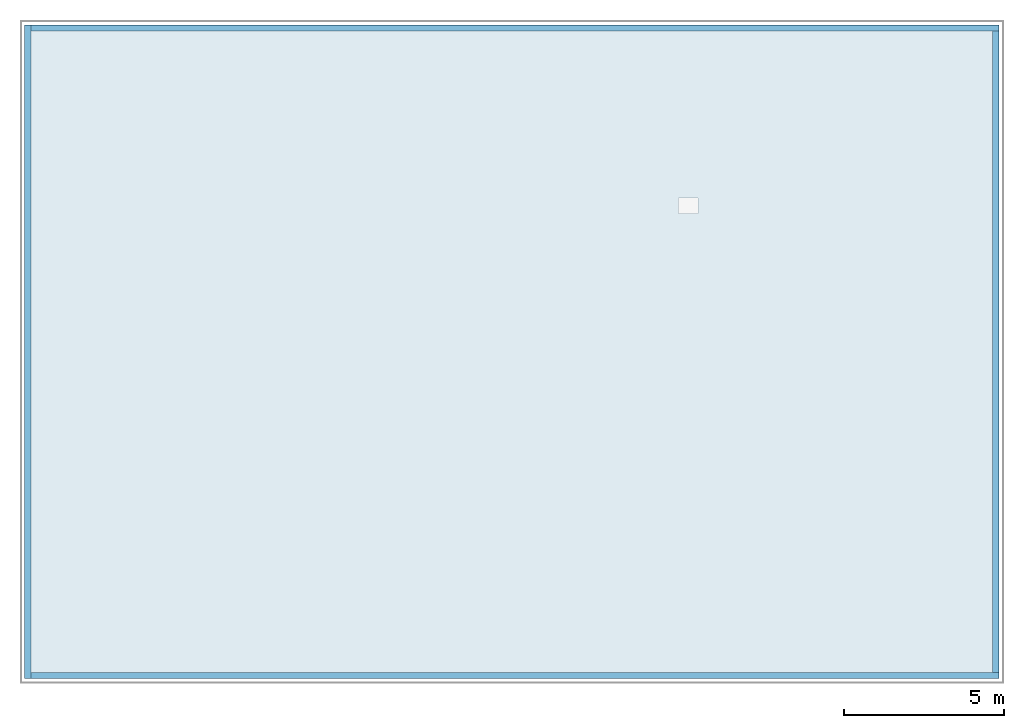
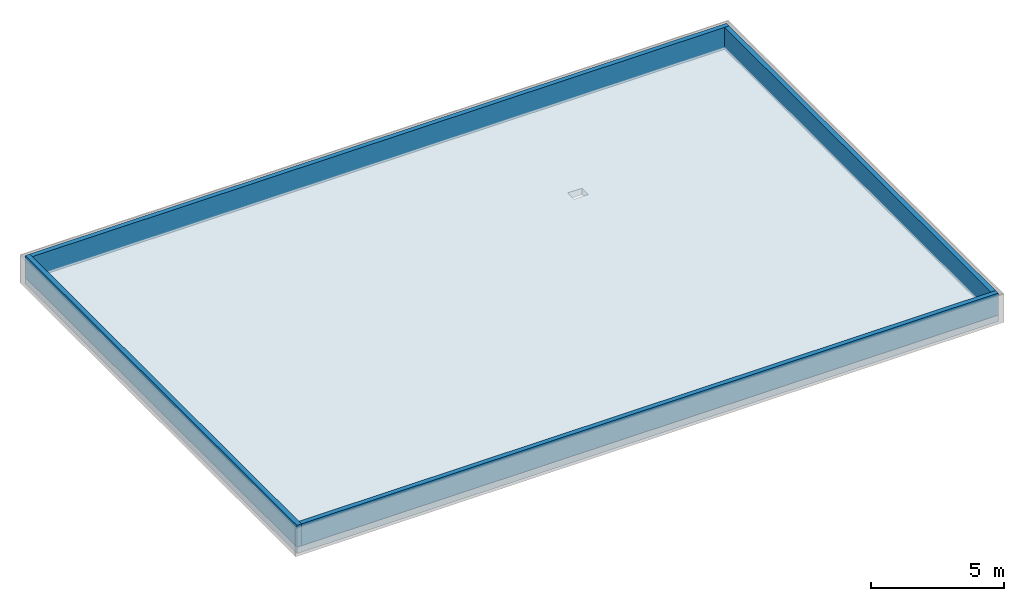
# One storey, part 1 of 2: 4 walls, 1 slab, 1 opening.
"""IFC2X3 building model written with IfcOpenShell, lengths in metres."""

from ifc_helpers import new_model, entity, si_unit, converted_unit, frame, frame_2d, origin, origin_with_axes, place, context, subcontext, project, spatial, rectangle, extrude, material, layer, layer_set, layer_usage, element, save


model = new_model("IFC2X3")

# Units and contexts
model_context = context("Model", 3, precision=1e-05, world=origin())
body_context = subcontext(model_context, "Body", "Model", "MODEL_VIEW")
ifc_project = project(units=[si_unit("LENGTHUNIT", "METRE"), si_unit("AREAUNIT", "SQUARE_METRE"), si_unit("VOLUMEUNIT", "CUBIC_METRE"), si_unit("MASSUNIT", "GRAM", prefix="KILO"), converted_unit("PLANEANGLEUNIT", "DEGREE", entity("IfcPlaneAngleMeasure", 0.0174532925199433), si_unit("PLANEANGLEUNIT", "RADIAN"), dimensions=[0, 0, 0, 0, 0, 0, 0])], contexts=[model_context])

# Site, building, storey
site_placement = place(None, origin())
site = spatial("IfcSite", under=ifc_project, at=site_placement, CompositionType="ELEMENT")
building_placement = place(site_placement, origin())
building = spatial("IfcBuilding", under=site, at=building_placement, CompositionType="ELEMENT")
storey_placement = place(building_placement, frame((0.0, 0.0, 19.5)))
storey = spatial("IfcBuildingStorey", under=building, at=storey_placement, Name="Dachgeschoss", CompositionType="ELEMENT", Elevation=19.5)

# Slab, opening
ifc_material_1 = material(Name="C25/30")
slab_placement = place(storey_placement, frame((2.95817792030736e-17, 2.8421709430404e-17, 0.0)))
slab = element("IfcSlab", 1, at=slab_placement, inside=storey, material=ifc_material_1, Name="Geschossdecke", PredefinedType="FLOOR", context=body_context, shape_type="SweptSolid", body=[
    extrude(rectangle(XDim=30.4, YDim=20.4, at=frame_2d((15.2, 10.2), x_axis=(1.0, 0.0))), origin_with_axes(), (0.0, 0.0, 1.0), 0.3),
])
opening_placement = place(slab_placement, frame((20.4, 14.52, 0.0)))
element("IfcOpeningElement", 2, at=opening_placement, cuts=slab, ObjectType="Opening", context=body_context, shape_type="SweptSolid", body=[
    extrude(rectangle(XDim=0.48, YDim=0.62, at=frame_2d((0.0, 0.0), x_axis=(0.0, -1.0))), frame((0.31, 0.24, 0.0), z_axis=(0.0, 0.0, 1.0), x_axis=(1.0, 0.0, 0.0)), (0.0, 0.0, 1.0), 0.3),
])

# Walls
ifc_material_2 = material(Name="C25/30")
ifc_layer_1 = layer(ifc_material_2, 0.2)
ifc_layer_set_1 = layer_set([ifc_layer_1])
ifc_layer_usage_1 = layer_usage(ifc_layer_set_1, "AXIS2", "POSITIVE", -0.2)
wall_1_placement = place(storey_placement, frame((0.2, 2.8421709430404e-17, 0.3), z_axis=(0.0, 0.0, 1.0), x_axis=(0.0, 1.0, 0.0)))
element("IfcWallStandardCase", 3, at=wall_1_placement, inside=storey, material=ifc_layer_usage_1, Name="IW Beton", context=body_context, shape_type="SweptSolid", body=[
    extrude(rectangle(XDim=20.4, YDim=0.2, at=frame_2d((10.2, 0.1), x_axis=(1.0, 0.0))), origin_with_axes(), (0.0, 0.0, 1.0), 1.0),
])
ifc_material_3 = material(Name="C25/30")
ifc_layer_2 = layer(ifc_material_3, 0.2)
ifc_layer_set_2 = layer_set([ifc_layer_2])
ifc_layer_usage_2 = layer_usage(ifc_layer_set_2, "AXIS2", "POSITIVE", -0.2)
wall_2_placement = place(storey_placement, frame((0.2, 20.2, 0.3)))
element("IfcWallStandardCase", 4, at=wall_2_placement, inside=storey, material=ifc_layer_usage_2, Name="IW Beton", context=body_context, shape_type="SweptSolid", body=[
    extrude(rectangle(XDim=30.2, YDim=0.2, at=frame_2d((15.1, 0.1), x_axis=(1.0, 0.0))), origin_with_axes(), (0.0, 0.0, 1.0), 1.0),
])
ifc_material_4 = material(Name="C25/30")
ifc_layer_3 = layer(ifc_material_4, 0.2)
ifc_layer_set_3 = layer_set([ifc_layer_3])
ifc_layer_usage_3 = layer_usage(ifc_layer_set_3, "AXIS2", "POSITIVE", -0.2)
wall_3_placement = place(storey_placement, frame((30.4, 0.2, 0.3), z_axis=(0.0, 0.0, 1.0), x_axis=(-1.0, 0.0, 0.0)))
element("IfcWallStandardCase", 5, at=wall_3_placement, inside=storey, material=ifc_layer_usage_3, Name="IW Beton", context=body_context, shape_type="SweptSolid", body=[
    extrude(rectangle(XDim=30.2, YDim=0.2, at=frame_2d((15.1, 0.1), x_axis=(1.0, 0.0))), origin_with_axes(), (0.0, 0.0, 1.0), 1.0),
])
ifc_material_5 = material(Name="C25/30")
ifc_layer_4 = layer(ifc_material_5, 0.2)
ifc_layer_set_4 = layer_set([ifc_layer_4])
ifc_layer_usage_4 = layer_usage(ifc_layer_set_4, "AXIS2", "POSITIVE", -0.2)
wall_4_placement = place(storey_placement, frame((30.2, 20.2, 0.3), z_axis=(0.0, 0.0, 1.0), x_axis=(0.0, -1.0, 0.0)))
element("IfcWallStandardCase", 6, at=wall_4_placement, inside=storey, material=ifc_layer_usage_4, Name="IW Beton", context=body_context, shape_type="SweptSolid", body=[
    extrude(rectangle(XDim=20.0, YDim=0.2, at=frame_2d((10.0, 0.1), x_axis=(1.0, 0.0))), origin_with_axes(), (0.0, 0.0, 1.0), 1.0),
])

save(model, "model.ifc")
